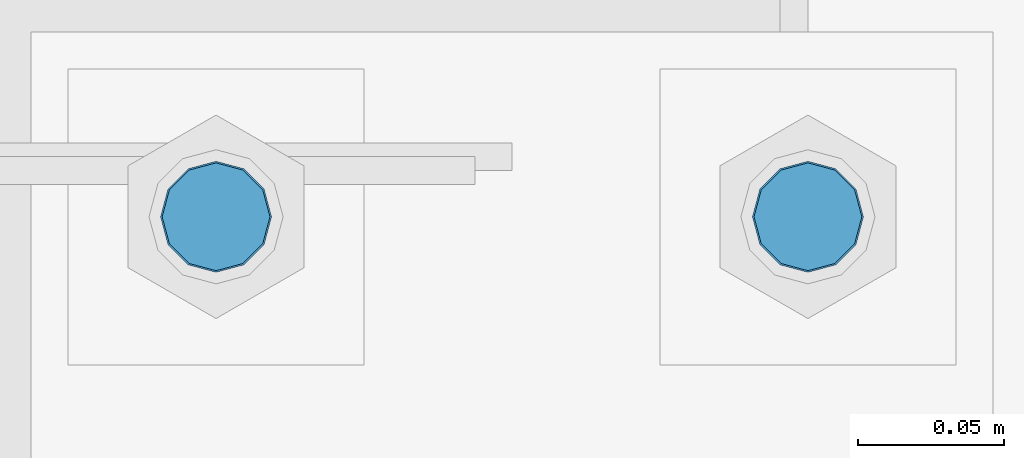
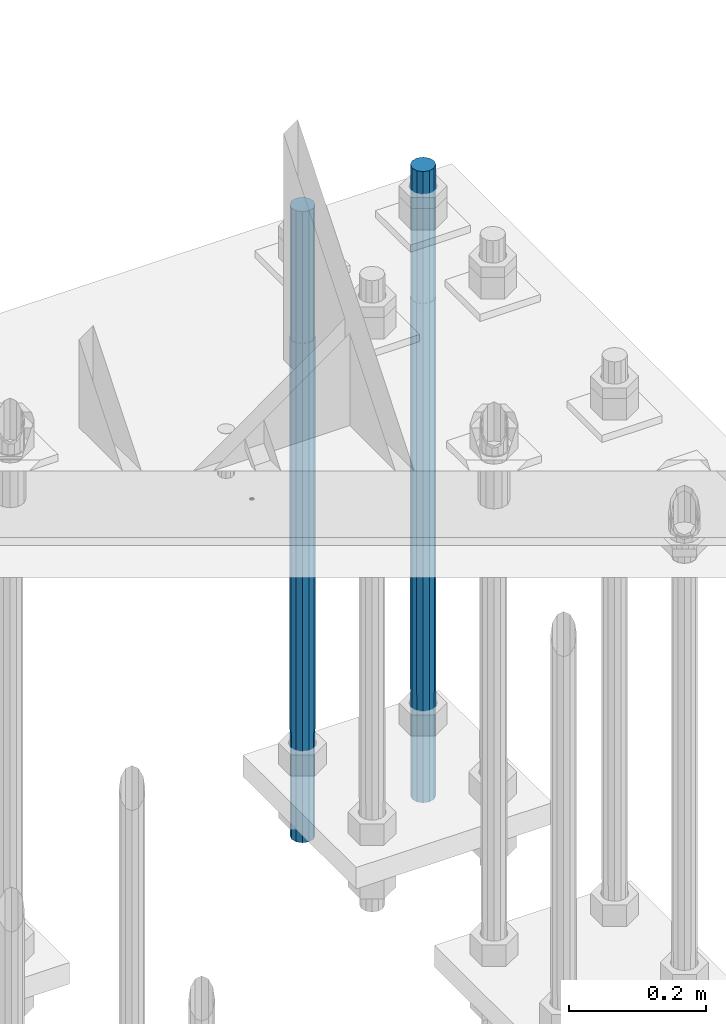
# One storey, part 1431 of 3843: 2 columns, 1 element without a shape of its own.
"""IFC2X3 building model written with IfcOpenShell, lengths in millimetres."""

from ifc_helpers import new_model, si_unit, frame, origin_with_axes, place, context, subcontext, project, spatial, faceted_brep, material, type_object, element, aggregate, save


model = new_model("IFC2X3")

# Units and contexts
model_context = context("Model", 3, precision=1e-05, world=origin_with_axes())
body_context = subcontext(model_context, "Body", "Model", "MODEL_VIEW")
ifc_project = project(units=[si_unit("LENGTHUNIT", "METRE", prefix="MILLI"), si_unit("AREAUNIT", "SQUARE_METRE"), si_unit("VOLUMEUNIT", "CUBIC_METRE"), si_unit("MASSUNIT", "GRAM", prefix="KILO"), si_unit("TIMEUNIT", "SECOND"), si_unit("PLANEANGLEUNIT", "RADIAN"), si_unit("SOLIDANGLEUNIT", "STERADIAN"), si_unit("THERMODYNAMICTEMPERATUREUNIT", "DEGREE_CELSIUS"), si_unit("LUMINOUSINTENSITYUNIT", "LUMEN")], contexts=[model_context])

# Site, building, storey
site_placement = place(None, origin_with_axes())
site = spatial("IfcSite", under=ifc_project, at=site_placement, CompositionType="ELEMENT")
building_placement = place(site_placement, origin_with_axes())
building = spatial("IfcBuilding", under=site, at=building_placement, Name="Undefined", CompositionType="ELEMENT")
storey_placement = place(building_placement, origin_with_axes())
storey = spatial("IfcBuildingStorey", under=building, at=storey_placement, Name="Undefined", CompositionType="ELEMENT", Elevation=0.0)

# Assembly, columns
assembly_placement = place(storey_placement, origin_with_axes())
assembly = element("IfcElementAssembly", 1, at=assembly_placement, inside=storey, Name="TEMPLATE", AssemblyPlace="NOTDEFINED", PredefinedType="RIGID_FRAME")
ifc_material = material(Name="Undefined/F1554-GR.55")
column_type = type_object("IfcColumnType", PredefinedType="NOTDEFINED")
column_1_placement = place(assembly_placement, frame((86156.8, 104940.1, 29565.6), z_axis=(-1.0, 0.0, 0.0), x_axis=(0.0, 0.0, -1.0)))
column_1 = element("IfcColumn", 2, at=column_1_placement, type_object=column_type, material=ifc_material, Name="ANCHOR_ROD", context=body_context, shape_type="Brep", body=[
    faceted_brep([(-234.950000000001, -16.0214699700155, 9.25), (-234.950000000001, -9.25, 16.0214699700155), (-234.950000000001, 0.0, 18.5), (-234.950000000001, 9.25, 16.0214699700155), (-234.950000000001, 16.0214699700155, 9.25), (-234.950000000001, 18.5, 0.0), (-234.950000000001, 16.0214699700155, -9.25), (-234.950000000001, 9.25, -16.0214699700155), (-234.950000000001, 0.0, -18.5), (-234.950000000001, -9.25, -16.0214699700155), (-234.950000000001, -16.0214699700155, -9.25), (-234.950000000001, -18.5, 0.0), (0.0, 18.5, 0.0), (0.0, 16.0214699700118, -9.25), (0.0, 9.25, -16.0214699700155), (0.0, 0.0, -18.5), (0.0, -9.25, -16.0214699700155), (0.0, -16.0214699700118, -9.25), (0.0, -18.5, 0.0), (0.0, -16.0214699700118, 9.25), (0.0, -9.25, 16.0214699700155), (0.0, 0.0, 18.5), (0.0, 9.25, 16.0214699700155), (0.0, 16.0214699700118, 9.25), (0.0, -16.4977839420972, 9.52500000000146), (0.0, -9.52500000000146, 16.4977839420972), (0.0, 0.0, 19.0499989999989), (0.0, 9.52500000000146, 16.4977839420972), (0.0, 16.4977839420972, 9.52500000000146), (0.0, 19.0500000000029, 0.0), (0.0, 16.4977839420972, -9.52500000000146), (0.0, 9.52500000000146, -16.4977839420972), (0.0, 0.0, -19.0499989999989), (0.0, -9.52500000000146, -16.4977839420972), (0.0, -16.4977839420972, -9.52500000000146), (0.0, -19.0500000000029, 0.0), (698.5, -19.0499999999993, 0.0), (698.5, -16.4977839420935, 9.52499999999418), (698.5, -9.52500000000146, 16.4977839420899), (698.5, 0.0, 19.0500000000029), (698.5, 9.52500000000146, 16.4977839420899), (698.5, 16.4977839420935, 9.52499999999418), (698.5, 19.0499999999993, 0.0), (698.5, 16.4977839420935, -9.52499999999418), (698.5, 9.52500000000146, -16.4977839420899), (698.5, 0.0, -19.0500000000029), (698.5, -9.52500000000146, -16.4977839420899), (698.5, -16.4977839420935, -9.52499999999418), (698.5, -9.25, 16.0214699700155), (698.5, 0.0, 18.5), (698.5, 9.25, 16.0214699700155), (698.5, 16.0214699700118, 9.25), (698.5, 18.5, 0.0), (698.5, 16.0214699700118, -9.25), (698.5, 9.25, -16.0214699700155), (698.5, 0.0, -18.5), (698.5, -9.25, -16.0214699700155), (698.5, -16.0214699700118, -9.25), (698.5, -18.5, 0.0), (698.5, -16.0214699700118, 9.25), (889.0, -9.25, -16.0214699700155), (889.0, 0.0, -18.5), (889.0, 9.25, -16.0214699700155), (889.0, 16.0214699700118, -9.25), (889.0, 18.5, 0.0), (889.0, 16.0214699700118, 9.25), (889.0, 9.25, 16.0214699700155), (889.0, 0.0, 18.5), (889.0, -9.25, 16.0214699700155), (889.0, -16.0214699700118, 9.25), (889.0, -18.5, 0.0), (889.0, -16.0214699700118, -9.25)], [[[0, 1, 2, 3, 4, 5, 6, 7, 8, 9, 10, 11]], [[6, 5, 12, 13]], [[7, 6, 13, 14]], [[8, 7, 14, 15]], [[9, 8, 15, 16]], [[10, 9, 16, 17]], [[11, 10, 17, 18]], [[0, 11, 18, 19]], [[1, 0, 19, 20]], [[2, 1, 20, 21]], [[3, 2, 21, 22]], [[4, 3, 22, 23]], [[5, 4, 23, 12]], [[24, 25, 26, 27, 28, 29, 30, 31, 32, 33, 34, 35], [22, 21, 20, 19, 18, 17, 16, 15, 14, 13, 12, 23]], [[24, 35, 36, 37]], [[25, 24, 37, 38]], [[26, 25, 38, 39]], [[27, 26, 39, 40]], [[28, 27, 40, 41]], [[29, 28, 41, 42]], [[30, 29, 42, 43]], [[31, 30, 43, 44]], [[32, 31, 44, 45]], [[33, 32, 45, 46]], [[34, 33, 46, 47]], [[35, 34, 47, 36]], [[46, 45, 44, 43, 42, 41, 40, 39, 38, 37, 36, 47], [48, 49, 50, 51, 52, 53, 54, 55, 56, 57, 58, 59]], [[60, 61, 62, 63, 64, 65, 66, 67, 68, 69, 70, 71]], [[68, 67, 49, 48]], [[69, 68, 48, 59]], [[70, 69, 59, 58]], [[71, 70, 58, 57]], [[60, 71, 57, 56]], [[61, 60, 56, 55]], [[62, 61, 55, 54]], [[63, 62, 54, 53]], [[64, 63, 53, 52]], [[65, 64, 52, 51]], [[66, 65, 51, 50]], [[67, 66, 50, 49]]]),
])
column_2_placement = place(assembly_placement, frame((85953.6, 104940.1, 29565.6), z_axis=(-1.0, 0.0, 0.0), x_axis=(0.0, 0.0, -1.0)))
column_2 = element("IfcColumn", 3, at=column_2_placement, type_object=column_type, material=ifc_material, Name="ANCHOR_ROD", context=body_context, shape_type="Brep", body=[
    faceted_brep([(-234.950000000001, -16.0214699700155, 9.25), (-234.950000000001, -9.25, 16.0214699700155), (-234.950000000001, 0.0, 18.5), (-234.950000000001, 9.25, 16.0214699700155), (-234.950000000001, 16.0214699700155, 9.25), (-234.950000000001, 18.5, 0.0), (-234.950000000001, 16.0214699700155, -9.25), (-234.950000000001, 9.25, -16.0214699700155), (-234.950000000001, 0.0, -18.5), (-234.950000000001, -9.25, -16.0214699700155), (-234.950000000001, -16.0214699700155, -9.25), (-234.950000000001, -18.5, 0.0), (0.0, 18.5, 0.0), (0.0, 16.0214699700118, -9.25), (0.0, 9.25, -16.0214699700155), (0.0, 0.0, -18.5), (0.0, -9.25, -16.0214699700155), (0.0, -16.0214699700118, -9.25), (0.0, -18.5, 0.0), (0.0, -16.0214699700118, 9.25), (0.0, -9.25, 16.0214699700155), (0.0, 0.0, 18.5), (0.0, 9.25, 16.0214699700155), (0.0, 16.0214699700118, 9.25), (0.0, -16.4977839420972, 9.52500000000146), (0.0, -9.52500000000146, 16.4977839420972), (0.0, 0.0, 19.0499989999989), (0.0, 9.52500000000146, 16.4977839420972), (0.0, 16.4977839420972, 9.52500000000146), (0.0, 19.0500000000029, 0.0), (0.0, 16.4977839420972, -9.52500000000146), (0.0, 9.52500000000146, -16.4977839420972), (0.0, 0.0, -19.0499989999989), (0.0, -9.52500000000146, -16.4977839420972), (0.0, -16.4977839420972, -9.52500000000146), (0.0, -19.0500000000029, 0.0), (698.5, -19.0499999999993, 0.0), (698.5, -16.4977839420935, 9.52499999999418), (698.5, -9.52500000000146, 16.4977839420899), (698.5, 0.0, 19.0500000000029), (698.5, 9.52500000000146, 16.4977839420899), (698.5, 16.4977839420935, 9.52499999999418), (698.5, 19.0499999999993, 0.0), (698.5, 16.4977839420935, -9.52499999999418), (698.5, 9.52500000000146, -16.4977839420899), (698.5, 0.0, -19.0500000000029), (698.5, -9.52500000000146, -16.4977839420899), (698.5, -16.4977839420935, -9.52499999999418), (698.5, -9.25, 16.0214699700155), (698.5, 0.0, 18.5), (698.5, 9.25, 16.0214699700155), (698.5, 16.0214699700118, 9.25), (698.5, 18.5, 0.0), (698.5, 16.0214699700118, -9.25), (698.5, 9.25, -16.0214699700155), (698.5, 0.0, -18.5), (698.5, -9.25, -16.0214699700155), (698.5, -16.0214699700118, -9.25), (698.5, -18.5, 0.0), (698.5, -16.0214699700118, 9.25), (889.0, -9.25, -16.0214699700155), (889.0, 0.0, -18.5), (889.0, 9.25, -16.0214699700155), (889.0, 16.0214699700118, -9.25), (889.0, 18.5, 0.0), (889.0, 16.0214699700118, 9.25), (889.0, 9.25, 16.0214699700155), (889.0, 0.0, 18.5), (889.0, -9.25, 16.0214699700155), (889.0, -16.0214699700118, 9.25), (889.0, -18.5, 0.0), (889.0, -16.0214699700118, -9.25)], [[[0, 1, 2, 3, 4, 5, 6, 7, 8, 9, 10, 11]], [[6, 5, 12, 13]], [[7, 6, 13, 14]], [[8, 7, 14, 15]], [[9, 8, 15, 16]], [[10, 9, 16, 17]], [[11, 10, 17, 18]], [[0, 11, 18, 19]], [[1, 0, 19, 20]], [[2, 1, 20, 21]], [[3, 2, 21, 22]], [[4, 3, 22, 23]], [[5, 4, 23, 12]], [[24, 25, 26, 27, 28, 29, 30, 31, 32, 33, 34, 35], [22, 21, 20, 19, 18, 17, 16, 15, 14, 13, 12, 23]], [[24, 35, 36, 37]], [[25, 24, 37, 38]], [[26, 25, 38, 39]], [[27, 26, 39, 40]], [[28, 27, 40, 41]], [[29, 28, 41, 42]], [[30, 29, 42, 43]], [[31, 30, 43, 44]], [[32, 31, 44, 45]], [[33, 32, 45, 46]], [[34, 33, 46, 47]], [[35, 34, 47, 36]], [[46, 45, 44, 43, 42, 41, 40, 39, 38, 37, 36, 47], [48, 49, 50, 51, 52, 53, 54, 55, 56, 57, 58, 59]], [[60, 61, 62, 63, 64, 65, 66, 67, 68, 69, 70, 71]], [[68, 67, 49, 48]], [[69, 68, 48, 59]], [[70, 69, 59, 58]], [[71, 70, 58, 57]], [[60, 71, 57, 56]], [[61, 60, 56, 55]], [[62, 61, 55, 54]], [[63, 62, 54, 53]], [[64, 63, 53, 52]], [[65, 64, 52, 51]], [[66, 65, 51, 50]], [[67, 66, 50, 49]]]),
])
aggregate(assembly, [column_1, column_2])

save(model, "model.ifc")
